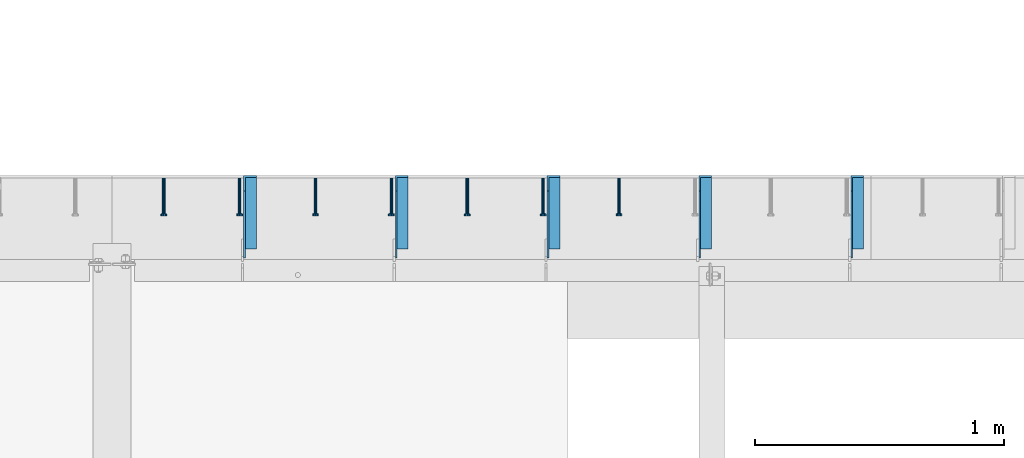
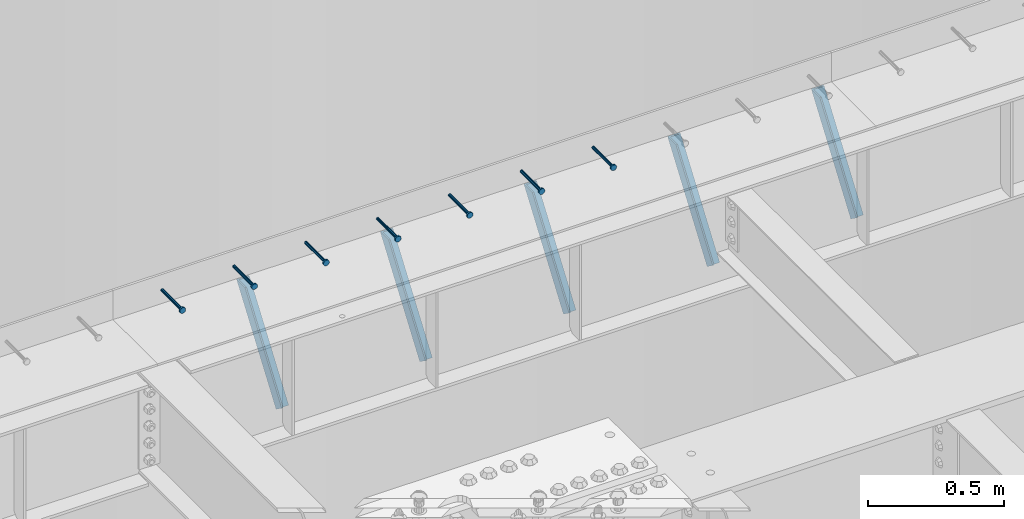
# One storey, part 1355 of 1763: 7 beams, 5 members, 8 elements without a shape of their own.
"""IFC2X3 building model written with IfcOpenShell, lengths in millimetres."""

from ifc_helpers import new_model, si_unit, frame, origin_with_axes, place, context, subcontext, project, spatial, faceted_brep, material, type_object, element, aggregate, save


model = new_model("IFC2X3")

# Units and contexts
model_context = context("Model", 3, precision=1e-05, world=origin_with_axes())
body_context = subcontext(model_context, "Body", "Model", "MODEL_VIEW")
ifc_project = project(units=[si_unit("LENGTHUNIT", "METRE", prefix="MILLI"), si_unit("AREAUNIT", "SQUARE_METRE"), si_unit("VOLUMEUNIT", "CUBIC_METRE"), si_unit("MASSUNIT", "GRAM", prefix="KILO"), si_unit("TIMEUNIT", "SECOND"), si_unit("PLANEANGLEUNIT", "RADIAN"), si_unit("SOLIDANGLEUNIT", "STERADIAN"), si_unit("THERMODYNAMICTEMPERATUREUNIT", "DEGREE_CELSIUS"), si_unit("LUMINOUSINTENSITYUNIT", "LUMEN")], contexts=[model_context])

# Site, building, storey
site_placement = place(None, origin_with_axes())
site = spatial("IfcSite", under=ifc_project, at=site_placement, CompositionType="ELEMENT")
building_placement = place(site_placement, origin_with_axes())
building = spatial("IfcBuilding", under=site, at=building_placement, Name="Undefined", CompositionType="ELEMENT")
storey_placement = place(building_placement, origin_with_axes())
storey = spatial("IfcBuildingStorey", under=building, at=storey_placement, Name="Undefined", CompositionType="ELEMENT", Elevation=0.0)

# Assembly, beam
assembly_1_placement = place(storey_placement, origin_with_axes())
assembly_1 = element("IfcElementAssembly", 1, at=assembly_1_placement, inside=storey, Name="HEADED STUD ANCHOR", AssemblyPlace="NOTDEFINED", PredefinedType="RIGID_FRAME")
ifc_material_1 = material(Name="STEEL/A108")
beam_type = type_object("IfcBeamType", PredefinedType="NOTDEFINED")
beam_1_placement = place(assembly_1_placement, frame((-47365.6747736983, 53984.5250183106, 5264.23140606069), z_axis=(0.0, 0.0, 1.0), x_axis=(0.0, -1.0, 0.0)))
beam_1 = element("IfcBeam", 2, at=beam_1_placement, type_object=beam_type, material=ifc_material_1, Name="HEADED STUD ANCHOR", context=body_context, shape_type="Brep", body=[
    faceted_brep([(0.0, -3.1800000667572, 5.5), (0.0, -5.5, 3.1800000667572), (141.732000000002, -5.5, 3.1800000667572), (141.732000000002, -3.1800000667572, 5.5), (0.0, -6.34999999999491, 1.45519152283669e-11), (141.732000000002, -6.34999990463257, 0.0), (0.0, -5.5, -3.1800000667572), (141.732000000002, -5.5, -3.1800000667572), (0.0, -3.1800000667572, -5.5), (141.732000000002, -3.1800000667572, -5.5), (0.0, 0.0, -6.34999990463257), (141.732000000002, 0.0, -6.34999990463257), (0.0, 3.1800000667572, -5.5), (141.732000000002, 3.1800000667572, -5.5), (0.0, 5.5, -3.1800000667572), (141.732000000002, 5.5, -3.1800000667572), (0.0, 6.34999999999491, -2.91038304567337e-11), (141.732000000002, 6.34999990463257, 0.0), (0.0, 5.5, 3.1800000667572), (141.732000000002, 5.5, 3.1800000667572), (0.0, 3.1800000667572, 5.5), (141.732000000002, 3.1800000667572, 5.5), (0.0, 0.0, 6.34999990463257), (141.732000000002, 0.0, 6.34999990463257), (144.780000000001, -10.9899997711182, 6.34999990463257), (144.780000000001, -6.34000015258789, 10.9899997711182), (144.780000000001, -12.6999998092651, 0.0), (144.780000000001, -10.9899997711182, -6.34999990463257), (144.780000000001, -6.34000015258789, -10.9899997711182), (144.780000000001, 0.0, -12.6899995803833), (144.780000000001, 6.34000015258789, -10.9899997711182), (144.780000000001, 10.9899997711182, -6.34999990463257), (144.780000000001, 12.6999998092651, 0.0), (144.780000000001, 10.9899997711182, 6.34999990463257), (144.780000000001, 6.34000015258789, 10.9899997711182), (144.780000000001, 0.0, 12.6899995803833), (152.400000000001, -10.9899997711182, 6.34999990463257), (152.400000000001, -6.34000015258789, 10.9899997711182), (152.400000000001, -12.6999998092651, 0.0), (152.400000000001, -10.9899997711182, -6.34999990463257), (152.400000000001, -6.34000015258789, -10.9899997711182), (152.400000000001, 0.0, -12.6899995803833), (152.400000000001, 6.34000015258789, -10.9899997711182), (152.400000000001, 10.9899997711182, -6.34999990463257), (152.400000000001, 12.6999998092651, 0.0), (152.400000000001, 10.9899997711182, 6.34999990463257), (152.400000000001, 6.34000015258789, 10.9899997711182), (152.400000000001, 0.0, 12.6899995803833)], [[[0, 1, 2, 3]], [[1, 4, 5, 2]], [[4, 6, 7, 5]], [[6, 8, 9, 7]], [[8, 10, 11, 9]], [[10, 12, 13, 11]], [[12, 14, 15, 13]], [[14, 16, 17, 15]], [[16, 18, 19, 17]], [[18, 20, 21, 19]], [[20, 22, 23, 21]], [[22, 0, 3, 23]], [[22, 20, 18, 16, 14, 12, 10, 8, 6, 4, 1, 0]], [[3, 2, 24, 25]], [[2, 5, 26, 24]], [[5, 7, 27, 26]], [[7, 9, 28, 27]], [[9, 11, 29, 28]], [[11, 13, 30, 29]], [[13, 15, 31, 30]], [[15, 17, 32, 31]], [[17, 19, 33, 32]], [[19, 21, 34, 33]], [[21, 23, 35, 34]], [[23, 3, 25, 35]], [[25, 24, 36, 37]], [[24, 26, 38, 36]], [[26, 27, 39, 38]], [[27, 28, 40, 39]], [[28, 29, 41, 40]], [[29, 30, 42, 41]], [[30, 31, 43, 42]], [[31, 32, 44, 43]], [[32, 33, 45, 44]], [[33, 34, 46, 45]], [[34, 35, 47, 46]], [[35, 25, 37, 47]], [[38, 39, 40, 41, 42, 43, 44, 45, 46, 47, 37, 36]]]),
])
aggregate(assembly_1, [beam_1])

assembly_2_placement = place(storey_placement, origin_with_axes())
assembly_2 = element("IfcElementAssembly", 3, at=assembly_2_placement, inside=storey, Name="HEADED STUD ANCHOR", AssemblyPlace="NOTDEFINED", PredefinedType="RIGID_FRAME")
beam_2_placement = place(assembly_2_placement, frame((-47670.4747736983, 53984.5250183106, 5264.23140606069), z_axis=(0.0, 0.0, 1.0), x_axis=(0.0, -1.0, 0.0)))
beam_2 = element("IfcBeam", 4, at=beam_2_placement, type_object=beam_type, material=ifc_material_1, Name="HEADED STUD ANCHOR", context=body_context, shape_type="Brep", body=[
    faceted_brep([(0.0, -3.1800000667572, 5.5), (0.0, -5.5, 3.1800000667572), (141.732000000002, -5.5, 3.1800000667572), (141.732000000002, -3.1800000667572, 5.5), (0.0, -6.34999999999491, 1.45519152283669e-11), (141.732000000002, -6.34999990463257, 0.0), (0.0, -5.5, -3.1800000667572), (141.732000000002, -5.5, -3.1800000667572), (0.0, -3.1800000667572, -5.5), (141.732000000002, -3.1800000667572, -5.5), (0.0, 0.0, -6.34999990463257), (141.732000000002, 0.0, -6.34999990463257), (0.0, 3.1800000667572, -5.5), (141.732000000002, 3.1800000667572, -5.5), (0.0, 5.5, -3.1800000667572), (141.732000000002, 5.5, -3.1800000667572), (0.0, 6.34999999999491, -2.91038304567337e-11), (141.732000000002, 6.34999990463257, 0.0), (0.0, 5.5, 3.1800000667572), (141.732000000002, 5.5, 3.1800000667572), (0.0, 3.1800000667572, 5.5), (141.732000000002, 3.1800000667572, 5.5), (0.0, 0.0, 6.34999990463257), (141.732000000002, 0.0, 6.34999990463257), (144.780000000001, -10.9899997711182, 6.34999990463257), (144.780000000001, -6.34000015258789, 10.9899997711182), (144.780000000001, -12.6999998092651, 0.0), (144.780000000001, -10.9899997711182, -6.34999990463257), (144.780000000001, -6.34000015258789, -10.9899997711182), (144.780000000001, 0.0, -12.6899995803833), (144.780000000001, 6.34000015258789, -10.9899997711182), (144.780000000001, 10.9899997711182, -6.34999990463257), (144.780000000001, 12.6999998092651, 0.0), (144.780000000001, 10.9899997711182, 6.34999990463257), (144.780000000001, 6.34000015258789, 10.9899997711182), (144.780000000001, 0.0, 12.6899995803833), (152.400000000001, -10.9899997711182, 6.34999990463257), (152.400000000001, -6.34000015258789, 10.9899997711182), (152.400000000001, -12.6999998092651, 0.0), (152.400000000001, -10.9899997711182, -6.34999990463257), (152.400000000001, -6.34000015258789, -10.9899997711182), (152.400000000001, 0.0, -12.6899995803833), (152.400000000001, 6.34000015258789, -10.9899997711182), (152.400000000001, 10.9899997711182, -6.34999990463257), (152.400000000001, 12.6999998092651, 0.0), (152.400000000001, 10.9899997711182, 6.34999990463257), (152.400000000001, 6.34000015258789, 10.9899997711182), (152.400000000001, 0.0, 12.6899995803833)], [[[0, 1, 2, 3]], [[1, 4, 5, 2]], [[4, 6, 7, 5]], [[6, 8, 9, 7]], [[8, 10, 11, 9]], [[10, 12, 13, 11]], [[12, 14, 15, 13]], [[14, 16, 17, 15]], [[16, 18, 19, 17]], [[18, 20, 21, 19]], [[20, 22, 23, 21]], [[22, 0, 3, 23]], [[22, 20, 18, 16, 14, 12, 10, 8, 6, 4, 1, 0]], [[3, 2, 24, 25]], [[2, 5, 26, 24]], [[5, 7, 27, 26]], [[7, 9, 28, 27]], [[9, 11, 29, 28]], [[11, 13, 30, 29]], [[13, 15, 31, 30]], [[15, 17, 32, 31]], [[17, 19, 33, 32]], [[19, 21, 34, 33]], [[21, 23, 35, 34]], [[23, 3, 25, 35]], [[25, 24, 36, 37]], [[24, 26, 38, 36]], [[26, 27, 39, 38]], [[27, 28, 40, 39]], [[28, 29, 41, 40]], [[29, 30, 42, 41]], [[30, 31, 43, 42]], [[31, 32, 44, 43]], [[32, 33, 45, 44]], [[33, 34, 46, 45]], [[34, 35, 47, 46]], [[35, 25, 37, 47]], [[38, 39, 40, 41, 42, 43, 44, 45, 46, 47, 37, 36]]]),
])
aggregate(assembly_2, [beam_2])

assembly_3_placement = place(storey_placement, origin_with_axes())
assembly_3 = element("IfcElementAssembly", 5, at=assembly_3_placement, inside=storey, Name="HEADED STUD ANCHOR", AssemblyPlace="NOTDEFINED", PredefinedType="RIGID_FRAME")
beam_3_placement = place(assembly_3_placement, frame((-47975.2747736983, 53984.5250183106, 5264.23140606069), z_axis=(0.0, 0.0, 1.0), x_axis=(0.0, -1.0, 0.0)))
beam_3 = element("IfcBeam", 6, at=beam_3_placement, type_object=beam_type, material=ifc_material_1, Name="HEADED STUD ANCHOR", context=body_context, shape_type="Brep", body=[
    faceted_brep([(0.0, -3.1800000667572, 5.5), (0.0, -5.5, 3.1800000667572), (141.732000000002, -5.5, 3.1800000667572), (141.732000000002, -3.1800000667572, 5.5), (0.0, -6.34999999999491, 1.45519152283669e-11), (141.732000000002, -6.34999990463257, 0.0), (0.0, -5.5, -3.1800000667572), (141.732000000002, -5.5, -3.1800000667572), (0.0, -3.1800000667572, -5.5), (141.732000000002, -3.1800000667572, -5.5), (0.0, 0.0, -6.34999990463257), (141.732000000002, 0.0, -6.34999990463257), (0.0, 3.1800000667572, -5.5), (141.732000000002, 3.1800000667572, -5.5), (0.0, 5.5, -3.1800000667572), (141.732000000002, 5.5, -3.1800000667572), (0.0, 6.34999999999491, -2.91038304567337e-11), (141.732000000002, 6.34999990463257, 0.0), (0.0, 5.5, 3.1800000667572), (141.732000000002, 5.5, 3.1800000667572), (0.0, 3.1800000667572, 5.5), (141.732000000002, 3.1800000667572, 5.5), (0.0, 0.0, 6.34999990463257), (141.732000000002, 0.0, 6.34999990463257), (144.780000000001, -10.9899997711182, 6.34999990463257), (144.780000000001, -6.34000015258789, 10.9899997711182), (144.780000000001, -12.6999998092651, 0.0), (144.780000000001, -10.9899997711182, -6.34999990463257), (144.780000000001, -6.34000015258789, -10.9899997711182), (144.780000000001, 0.0, -12.6899995803833), (144.780000000001, 6.34000015258789, -10.9899997711182), (144.780000000001, 10.9899997711182, -6.34999990463257), (144.780000000001, 12.6999998092651, 0.0), (144.780000000001, 10.9899997711182, 6.34999990463257), (144.780000000001, 6.34000015258789, 10.9899997711182), (144.780000000001, 0.0, 12.6899995803833), (152.400000000001, -10.9899997711182, 6.34999990463257), (152.400000000001, -6.34000015258789, 10.9899997711182), (152.400000000001, -12.6999998092651, 0.0), (152.400000000001, -10.9899997711182, -6.34999990463257), (152.400000000001, -6.34000015258789, -10.9899997711182), (152.400000000001, 0.0, -12.6899995803833), (152.400000000001, 6.34000015258789, -10.9899997711182), (152.400000000001, 10.9899997711182, -6.34999990463257), (152.400000000001, 12.6999998092651, 0.0), (152.400000000001, 10.9899997711182, 6.34999990463257), (152.400000000001, 6.34000015258789, 10.9899997711182), (152.400000000001, 0.0, 12.6899995803833)], [[[0, 1, 2, 3]], [[1, 4, 5, 2]], [[4, 6, 7, 5]], [[6, 8, 9, 7]], [[8, 10, 11, 9]], [[10, 12, 13, 11]], [[12, 14, 15, 13]], [[14, 16, 17, 15]], [[16, 18, 19, 17]], [[18, 20, 21, 19]], [[20, 22, 23, 21]], [[22, 0, 3, 23]], [[22, 20, 18, 16, 14, 12, 10, 8, 6, 4, 1, 0]], [[3, 2, 24, 25]], [[2, 5, 26, 24]], [[5, 7, 27, 26]], [[7, 9, 28, 27]], [[9, 11, 29, 28]], [[11, 13, 30, 29]], [[13, 15, 31, 30]], [[15, 17, 32, 31]], [[17, 19, 33, 32]], [[19, 21, 34, 33]], [[21, 23, 35, 34]], [[23, 3, 25, 35]], [[25, 24, 36, 37]], [[24, 26, 38, 36]], [[26, 27, 39, 38]], [[27, 28, 40, 39]], [[28, 29, 41, 40]], [[29, 30, 42, 41]], [[30, 31, 43, 42]], [[31, 32, 44, 43]], [[32, 33, 45, 44]], [[33, 34, 46, 45]], [[34, 35, 47, 46]], [[35, 25, 37, 47]], [[38, 39, 40, 41, 42, 43, 44, 45, 46, 47, 37, 36]]]),
])
aggregate(assembly_3, [beam_3])

assembly_4_placement = place(storey_placement, origin_with_axes())
assembly_4 = element("IfcElementAssembly", 7, at=assembly_4_placement, inside=storey, Name="HEADED STUD ANCHOR", AssemblyPlace="NOTDEFINED", PredefinedType="RIGID_FRAME")
beam_4_placement = place(assembly_4_placement, frame((-48280.0747736983, 53984.5250183106, 5264.23140606069), z_axis=(0.0, 0.0, 1.0), x_axis=(0.0, -1.0, 0.0)))
beam_4 = element("IfcBeam", 8, at=beam_4_placement, type_object=beam_type, material=ifc_material_1, Name="HEADED STUD ANCHOR", context=body_context, shape_type="Brep", body=[
    faceted_brep([(0.0, -3.1800000667572, 5.5), (0.0, -5.5, 3.1800000667572), (141.732000000002, -5.5, 3.1800000667572), (141.732000000002, -3.1800000667572, 5.5), (0.0, -6.34999999999491, 1.45519152283669e-11), (141.732000000002, -6.34999990463257, 0.0), (0.0, -5.5, -3.1800000667572), (141.732000000002, -5.5, -3.1800000667572), (0.0, -3.1800000667572, -5.5), (141.732000000002, -3.1800000667572, -5.5), (0.0, 0.0, -6.34999990463257), (141.732000000002, 0.0, -6.34999990463257), (0.0, 3.1800000667572, -5.5), (141.732000000002, 3.1800000667572, -5.5), (0.0, 5.5, -3.1800000667572), (141.732000000002, 5.5, -3.1800000667572), (0.0, 6.34999999999491, -2.91038304567337e-11), (141.732000000002, 6.34999990463257, 0.0), (0.0, 5.5, 3.1800000667572), (141.732000000002, 5.5, 3.1800000667572), (0.0, 3.1800000667572, 5.5), (141.732000000002, 3.1800000667572, 5.5), (0.0, 0.0, 6.34999990463257), (141.732000000002, 0.0, 6.34999990463257), (144.780000000001, -10.9899997711182, 6.34999990463257), (144.780000000001, -6.34000015258789, 10.9899997711182), (144.780000000001, -12.6999998092651, 0.0), (144.780000000001, -10.9899997711182, -6.34999990463257), (144.780000000001, -6.34000015258789, -10.9899997711182), (144.780000000001, 0.0, -12.6899995803833), (144.780000000001, 6.34000015258789, -10.9899997711182), (144.780000000001, 10.9899997711182, -6.34999990463257), (144.780000000001, 12.6999998092651, 0.0), (144.780000000001, 10.9899997711182, 6.34999990463257), (144.780000000001, 6.34000015258789, 10.9899997711182), (144.780000000001, 0.0, 12.6899995803833), (152.400000000001, -10.9899997711182, 6.34999990463257), (152.400000000001, -6.34000015258789, 10.9899997711182), (152.400000000001, -12.6999998092651, 0.0), (152.400000000001, -10.9899997711182, -6.34999990463257), (152.400000000001, -6.34000015258789, -10.9899997711182), (152.400000000001, 0.0, -12.6899995803833), (152.400000000001, 6.34000015258789, -10.9899997711182), (152.400000000001, 10.9899997711182, -6.34999990463257), (152.400000000001, 12.6999998092651, 0.0), (152.400000000001, 10.9899997711182, 6.34999990463257), (152.400000000001, 6.34000015258789, 10.9899997711182), (152.400000000001, 0.0, 12.6899995803833)], [[[0, 1, 2, 3]], [[1, 4, 5, 2]], [[4, 6, 7, 5]], [[6, 8, 9, 7]], [[8, 10, 11, 9]], [[10, 12, 13, 11]], [[12, 14, 15, 13]], [[14, 16, 17, 15]], [[16, 18, 19, 17]], [[18, 20, 21, 19]], [[20, 22, 23, 21]], [[22, 0, 3, 23]], [[22, 20, 18, 16, 14, 12, 10, 8, 6, 4, 1, 0]], [[3, 2, 24, 25]], [[2, 5, 26, 24]], [[5, 7, 27, 26]], [[7, 9, 28, 27]], [[9, 11, 29, 28]], [[11, 13, 30, 29]], [[13, 15, 31, 30]], [[15, 17, 32, 31]], [[17, 19, 33, 32]], [[19, 21, 34, 33]], [[21, 23, 35, 34]], [[23, 3, 25, 35]], [[25, 24, 36, 37]], [[24, 26, 38, 36]], [[26, 27, 39, 38]], [[27, 28, 40, 39]], [[28, 29, 41, 40]], [[29, 30, 42, 41]], [[30, 31, 43, 42]], [[31, 32, 44, 43]], [[32, 33, 45, 44]], [[33, 34, 46, 45]], [[34, 35, 47, 46]], [[35, 25, 37, 47]], [[38, 39, 40, 41, 42, 43, 44, 45, 46, 47, 37, 36]]]),
])
aggregate(assembly_4, [beam_4])

assembly_5_placement = place(storey_placement, origin_with_axes())
assembly_5 = element("IfcElementAssembly", 9, at=assembly_5_placement, inside=storey, Name="HEADED STUD ANCHOR", AssemblyPlace="NOTDEFINED", PredefinedType="RIGID_FRAME")
beam_5_placement = place(assembly_5_placement, frame((-48584.8747736983, 53984.5250183106, 5264.23140606069), z_axis=(0.0, 0.0, 1.0), x_axis=(0.0, -1.0, 0.0)))
beam_5 = element("IfcBeam", 10, at=beam_5_placement, type_object=beam_type, material=ifc_material_1, Name="HEADED STUD ANCHOR", context=body_context, shape_type="Brep", body=[
    faceted_brep([(0.0, -3.1800000667572, 5.5), (0.0, -5.5, 3.1800000667572), (141.732000000002, -5.5, 3.1800000667572), (141.732000000002, -3.1800000667572, 5.5), (0.0, -6.34999999999491, 1.45519152283669e-11), (141.732000000002, -6.34999990463257, 0.0), (0.0, -5.5, -3.1800000667572), (141.732000000002, -5.5, -3.1800000667572), (0.0, -3.1800000667572, -5.5), (141.732000000002, -3.1800000667572, -5.5), (0.0, 0.0, -6.34999990463257), (141.732000000002, 0.0, -6.34999990463257), (0.0, 3.1800000667572, -5.5), (141.732000000002, 3.1800000667572, -5.5), (0.0, 5.5, -3.1800000667572), (141.732000000002, 5.5, -3.1800000667572), (0.0, 6.34999999999491, -2.91038304567337e-11), (141.732000000002, 6.34999990463257, 0.0), (0.0, 5.5, 3.1800000667572), (141.732000000002, 5.5, 3.1800000667572), (0.0, 3.1800000667572, 5.5), (141.732000000002, 3.1800000667572, 5.5), (0.0, 0.0, 6.34999990463257), (141.732000000002, 0.0, 6.34999990463257), (144.780000000001, -10.9899997711182, 6.34999990463257), (144.780000000001, -6.34000015258789, 10.9899997711182), (144.780000000001, -12.6999998092651, 0.0), (144.780000000001, -10.9899997711182, -6.34999990463257), (144.780000000001, -6.34000015258789, -10.9899997711182), (144.780000000001, 0.0, -12.6899995803833), (144.780000000001, 6.34000015258789, -10.9899997711182), (144.780000000001, 10.9899997711182, -6.34999990463257), (144.780000000001, 12.6999998092651, 0.0), (144.780000000001, 10.9899997711182, 6.34999990463257), (144.780000000001, 6.34000015258789, 10.9899997711182), (144.780000000001, 0.0, 12.6899995803833), (152.400000000001, -10.9899997711182, 6.34999990463257), (152.400000000001, -6.34000015258789, 10.9899997711182), (152.400000000001, -12.6999998092651, 0.0), (152.400000000001, -10.9899997711182, -6.34999990463257), (152.400000000001, -6.34000015258789, -10.9899997711182), (152.400000000001, 0.0, -12.6899995803833), (152.400000000001, 6.34000015258789, -10.9899997711182), (152.400000000001, 10.9899997711182, -6.34999990463257), (152.400000000001, 12.6999998092651, 0.0), (152.400000000001, 10.9899997711182, 6.34999990463257), (152.400000000001, 6.34000015258789, 10.9899997711182), (152.400000000001, 0.0, 12.6899995803833)], [[[0, 1, 2, 3]], [[1, 4, 5, 2]], [[4, 6, 7, 5]], [[6, 8, 9, 7]], [[8, 10, 11, 9]], [[10, 12, 13, 11]], [[12, 14, 15, 13]], [[14, 16, 17, 15]], [[16, 18, 19, 17]], [[18, 20, 21, 19]], [[20, 22, 23, 21]], [[22, 0, 3, 23]], [[22, 20, 18, 16, 14, 12, 10, 8, 6, 4, 1, 0]], [[3, 2, 24, 25]], [[2, 5, 26, 24]], [[5, 7, 27, 26]], [[7, 9, 28, 27]], [[9, 11, 29, 28]], [[11, 13, 30, 29]], [[13, 15, 31, 30]], [[15, 17, 32, 31]], [[17, 19, 33, 32]], [[19, 21, 34, 33]], [[21, 23, 35, 34]], [[23, 3, 25, 35]], [[25, 24, 36, 37]], [[24, 26, 38, 36]], [[26, 27, 39, 38]], [[27, 28, 40, 39]], [[28, 29, 41, 40]], [[29, 30, 42, 41]], [[30, 31, 43, 42]], [[31, 32, 44, 43]], [[32, 33, 45, 44]], [[33, 34, 46, 45]], [[34, 35, 47, 46]], [[35, 25, 37, 47]], [[38, 39, 40, 41, 42, 43, 44, 45, 46, 47, 37, 36]]]),
])
aggregate(assembly_5, [beam_5])

assembly_6_placement = place(storey_placement, origin_with_axes())
assembly_6 = element("IfcElementAssembly", 11, at=assembly_6_placement, inside=storey, Name="HEADED STUD ANCHOR", AssemblyPlace="NOTDEFINED", PredefinedType="RIGID_FRAME")
beam_6_placement = place(assembly_6_placement, frame((-48889.6747736983, 53984.5250183106, 5264.23140606069), z_axis=(0.0, 0.0, 1.0), x_axis=(0.0, -1.0, 0.0)))
beam_6 = element("IfcBeam", 12, at=beam_6_placement, type_object=beam_type, material=ifc_material_1, Name="HEADED STUD ANCHOR", context=body_context, shape_type="Brep", body=[
    faceted_brep([(0.0, -3.1800000667572, 5.5), (0.0, -5.5, 3.1800000667572), (141.732000000002, -5.5, 3.1800000667572), (141.732000000002, -3.1800000667572, 5.5), (0.0, -6.34999999999491, 1.45519152283669e-11), (141.732000000002, -6.34999990463257, 0.0), (0.0, -5.5, -3.1800000667572), (141.732000000002, -5.5, -3.1800000667572), (0.0, -3.1800000667572, -5.5), (141.732000000002, -3.1800000667572, -5.5), (0.0, 0.0, -6.34999990463257), (141.732000000002, 0.0, -6.34999990463257), (0.0, 3.1800000667572, -5.5), (141.732000000002, 3.1800000667572, -5.5), (0.0, 5.5, -3.1800000667572), (141.732000000002, 5.5, -3.1800000667572), (0.0, 6.34999999999491, -2.91038304567337e-11), (141.732000000002, 6.34999990463257, 0.0), (0.0, 5.5, 3.1800000667572), (141.732000000002, 5.5, 3.1800000667572), (0.0, 3.1800000667572, 5.5), (141.732000000002, 3.1800000667572, 5.5), (0.0, 0.0, 6.34999990463257), (141.732000000002, 0.0, 6.34999990463257), (144.780000000001, -10.9899997711182, 6.34999990463257), (144.780000000001, -6.34000015258789, 10.9899997711182), (144.780000000001, -12.6999998092651, 0.0), (144.780000000001, -10.9899997711182, -6.34999990463257), (144.780000000001, -6.34000015258789, -10.9899997711182), (144.780000000001, 0.0, -12.6899995803833), (144.780000000001, 6.34000015258789, -10.9899997711182), (144.780000000001, 10.9899997711182, -6.34999990463257), (144.780000000001, 12.6999998092651, 0.0), (144.780000000001, 10.9899997711182, 6.34999990463257), (144.780000000001, 6.34000015258789, 10.9899997711182), (144.780000000001, 0.0, 12.6899995803833), (152.400000000001, -10.9899997711182, 6.34999990463257), (152.400000000001, -6.34000015258789, 10.9899997711182), (152.400000000001, -12.6999998092651, 0.0), (152.400000000001, -10.9899997711182, -6.34999990463257), (152.400000000001, -6.34000015258789, -10.9899997711182), (152.400000000001, 0.0, -12.6899995803833), (152.400000000001, 6.34000015258789, -10.9899997711182), (152.400000000001, 10.9899997711182, -6.34999990463257), (152.400000000001, 12.6999998092651, 0.0), (152.400000000001, 10.9899997711182, 6.34999990463257), (152.400000000001, 6.34000015258789, 10.9899997711182), (152.400000000001, 0.0, 12.6899995803833)], [[[0, 1, 2, 3]], [[1, 4, 5, 2]], [[4, 6, 7, 5]], [[6, 8, 9, 7]], [[8, 10, 11, 9]], [[10, 12, 13, 11]], [[12, 14, 15, 13]], [[14, 16, 17, 15]], [[16, 18, 19, 17]], [[18, 20, 21, 19]], [[20, 22, 23, 21]], [[22, 0, 3, 23]], [[22, 20, 18, 16, 14, 12, 10, 8, 6, 4, 1, 0]], [[3, 2, 24, 25]], [[2, 5, 26, 24]], [[5, 7, 27, 26]], [[7, 9, 28, 27]], [[9, 11, 29, 28]], [[11, 13, 30, 29]], [[13, 15, 31, 30]], [[15, 17, 32, 31]], [[17, 19, 33, 32]], [[19, 21, 34, 33]], [[21, 23, 35, 34]], [[23, 3, 25, 35]], [[25, 24, 36, 37]], [[24, 26, 38, 36]], [[26, 27, 39, 38]], [[27, 28, 40, 39]], [[28, 29, 41, 40]], [[29, 30, 42, 41]], [[30, 31, 43, 42]], [[31, 32, 44, 43]], [[32, 33, 45, 44]], [[33, 34, 46, 45]], [[34, 35, 47, 46]], [[35, 25, 37, 47]], [[38, 39, 40, 41, 42, 43, 44, 45, 46, 47, 37, 36]]]),
])
aggregate(assembly_6, [beam_6])

assembly_7_placement = place(storey_placement, origin_with_axes())
assembly_7 = element("IfcElementAssembly", 13, at=assembly_7_placement, inside=storey, Name="HEADED STUD ANCHOR", AssemblyPlace="NOTDEFINED", PredefinedType="RIGID_FRAME")
beam_7_placement = place(assembly_7_placement, frame((-49194.4747736983, 53984.5250183106, 5264.23140606069), z_axis=(0.0, 0.0, 1.0), x_axis=(0.0, -1.0, 0.0)))
beam_7 = element("IfcBeam", 14, at=beam_7_placement, type_object=beam_type, material=ifc_material_1, Name="HEADED STUD ANCHOR", context=body_context, shape_type="Brep", body=[
    faceted_brep([(0.0, -3.1800000667572, 5.5), (0.0, -5.5, 3.1800000667572), (141.732000000002, -5.5, 3.1800000667572), (141.732000000002, -3.1800000667572, 5.5), (0.0, -6.34999999999491, 1.45519152283669e-11), (141.732000000002, -6.34999990463257, 0.0), (0.0, -5.5, -3.1800000667572), (141.732000000002, -5.5, -3.1800000667572), (0.0, -3.1800000667572, -5.5), (141.732000000002, -3.1800000667572, -5.5), (0.0, 0.0, -6.34999990463257), (141.732000000002, 0.0, -6.34999990463257), (0.0, 3.1800000667572, -5.5), (141.732000000002, 3.1800000667572, -5.5), (0.0, 5.5, -3.1800000667572), (141.732000000002, 5.5, -3.1800000667572), (0.0, 6.34999999999491, -2.91038304567337e-11), (141.732000000002, 6.34999990463257, 0.0), (0.0, 5.5, 3.1800000667572), (141.732000000002, 5.5, 3.1800000667572), (0.0, 3.1800000667572, 5.5), (141.732000000002, 3.1800000667572, 5.5), (0.0, 0.0, 6.34999990463257), (141.732000000002, 0.0, 6.34999990463257), (144.780000000001, -10.9899997711182, 6.34999990463257), (144.780000000001, -6.34000015258789, 10.9899997711182), (144.780000000001, -12.6999998092651, 0.0), (144.780000000001, -10.9899997711182, -6.34999990463257), (144.780000000001, -6.34000015258789, -10.9899997711182), (144.780000000001, 0.0, -12.6899995803833), (144.780000000001, 6.34000015258789, -10.9899997711182), (144.780000000001, 10.9899997711182, -6.34999990463257), (144.780000000001, 12.6999998092651, 0.0), (144.780000000001, 10.9899997711182, 6.34999990463257), (144.780000000001, 6.34000015258789, 10.9899997711182), (144.780000000001, 0.0, 12.6899995803833), (152.400000000001, -10.9899997711182, 6.34999990463257), (152.400000000001, -6.34000015258789, 10.9899997711182), (152.400000000001, -12.6999998092651, 0.0), (152.400000000001, -10.9899997711182, -6.34999990463257), (152.400000000001, -6.34000015258789, -10.9899997711182), (152.400000000001, 0.0, -12.6899995803833), (152.400000000001, 6.34000015258789, -10.9899997711182), (152.400000000001, 10.9899997711182, -6.34999990463257), (152.400000000001, 12.6999998092651, 0.0), (152.400000000001, 10.9899997711182, 6.34999990463257), (152.400000000001, 6.34000015258789, 10.9899997711182), (152.400000000001, 0.0, 12.6899995803833)], [[[0, 1, 2, 3]], [[1, 4, 5, 2]], [[4, 6, 7, 5]], [[6, 8, 9, 7]], [[8, 10, 11, 9]], [[10, 12, 13, 11]], [[12, 14, 15, 13]], [[14, 16, 17, 15]], [[16, 18, 19, 17]], [[18, 20, 21, 19]], [[20, 22, 23, 21]], [[22, 0, 3, 23]], [[22, 20, 18, 16, 14, 12, 10, 8, 6, 4, 1, 0]], [[3, 2, 24, 25]], [[2, 5, 26, 24]], [[5, 7, 27, 26]], [[7, 9, 28, 27]], [[9, 11, 29, 28]], [[11, 13, 30, 29]], [[13, 15, 31, 30]], [[15, 17, 32, 31]], [[17, 19, 33, 32]], [[19, 21, 34, 33]], [[21, 23, 35, 34]], [[23, 3, 25, 35]], [[25, 24, 36, 37]], [[24, 26, 38, 36]], [[26, 27, 39, 38]], [[27, 28, 40, 39]], [[28, 29, 41, 40]], [[29, 30, 42, 41]], [[30, 31, 43, 42]], [[31, 32, 44, 43]], [[32, 33, 45, 44]], [[33, 34, 46, 45]], [[34, 35, 47, 46]], [[35, 25, 37, 47]], [[38, 39, 40, 41, 42, 43, 44, 45, 46, 47, 37, 36]]]),
])
aggregate(assembly_7, [beam_7])

# Assembly, members
assembly_8_placement = place(storey_placement, origin_with_axes())
assembly_8 = element("IfcElementAssembly", 15, at=assembly_8_placement, inside=storey, Name="BEAM", AssemblyPlace="NOTDEFINED", PredefinedType="RIGID_FRAME")
ifc_material_2 = material(Name="STEEL/A36")
member_type = type_object("IfcMemberType", Name="L2X2X1/4", PredefinedType="NOTDEFINED")
member_1_placement = place(assembly_8_placement, frame((-47019.0044734054, 53682.708383399, 4801.55161052505), z_axis=(0.0, -0.814117947745209, 0.580699549818259), x_axis=(0.0, 0.58069954981826, 0.814117947745209)))
member_1 = element("IfcMember", 16, at=member_1_placement, type_object=member_type, material=ifc_material_2, Name="ANGLE", ObjectType="L2X2X1/4", context=body_context, shape_type="Brep", body=[
    faceted_brep([(-1.45519152283669e-11, 25.4000000000015, -25.3999999999869), (1.45519152283669e-11, 25.4000000000015, 25.3999999999796), (464.304493432646, 25.4000000000015, 25.3999999991429), (500.539460322936, 25.4000000000015, -25.4000000009546), (1.45519152283669e-11, 19.0499999999993, 25.3999999999796), (464.304493432646, 19.0500000000029, 25.3999999991429), (-7.27595761418343e-12, 19.0499999999993, -19.0499999999956), (496.010089461648, 19.0500000000029, -19.0500000009415), (-7.27595761418343e-12, -25.4000000000015, -19.0499999999956), (496.010089461648, -25.4000000000015, -19.0500000009415), (-1.45519152283669e-11, -25.4000000000015, -25.3999999999869), (500.539460322936, -25.4000000000015, -25.4000000009546)], [[[0, 1, 2, 3]], [[1, 4, 5, 2]], [[4, 6, 7, 5]], [[6, 8, 9, 7]], [[8, 10, 11, 9]], [[10, 0, 3, 11]], [[5, 7, 9, 11, 3, 2]], [[10, 8, 6, 4, 1, 0]]]),
])
member_2_placement = place(assembly_8_placement, frame((-48238.2044734054, 53682.7083833989, 4801.55161052503), z_axis=(0.0, -0.814117947745209, 0.580699549818259), x_axis=(0.0, 0.58069954981826, 0.814117947745209)))
member_2 = element("IfcMember", 17, at=member_2_placement, type_object=member_type, material=ifc_material_2, Name="ANGLE", ObjectType="L2X2X1/4", context=body_context, shape_type="Brep", body=[
    faceted_brep([(-1.45519152283669e-11, 25.4000000000015, -25.3999999999869), (1.45519152283669e-11, 25.4000000000015, 25.3999999999796), (464.304493432646, 25.4000000000015, 25.3999999991429), (500.539460322936, 25.4000000000015, -25.4000000009546), (1.45519152283669e-11, 19.0499999999993, 25.3999999999796), (464.304493432646, 19.0500000000029, 25.3999999991429), (-7.27595761418343e-12, 19.0499999999993, -19.0499999999956), (496.010089461648, 19.0500000000029, -19.0500000009415), (-7.27595761418343e-12, -25.4000000000015, -19.0499999999956), (496.010089461648, -25.4000000000015, -19.0500000009415), (-1.45519152283669e-11, -25.4000000000015, -25.3999999999869), (500.539460322936, -25.4000000000015, -25.4000000009546)], [[[0, 1, 2, 3]], [[1, 4, 5, 2]], [[4, 6, 7, 5]], [[6, 8, 9, 7]], [[8, 10, 11, 9]], [[10, 0, 3, 11]], [[5, 7, 9, 11, 3, 2]], [[10, 8, 6, 4, 1, 0]]]),
])
member_3_placement = place(assembly_8_placement, frame((-46409.4044734054, 53682.708383399, 4801.55161052505), z_axis=(0.0, -0.814117947745209, 0.580699549818259), x_axis=(0.0, 0.58069954981826, 0.814117947745209)))
member_3 = element("IfcMember", 18, at=member_3_placement, type_object=member_type, material=ifc_material_2, Name="ANGLE", ObjectType="L2X2X1/4", context=body_context, shape_type="Brep", body=[
    faceted_brep([(-1.45519152283669e-11, 25.4000000000015, -25.3999999999869), (1.45519152283669e-11, 25.4000000000015, 25.3999999999796), (464.304493432646, 25.4000000000015, 25.3999999991429), (500.539460322936, 25.4000000000015, -25.4000000009546), (1.45519152283669e-11, 19.0499999999993, 25.3999999999796), (464.304493432646, 19.0500000000029, 25.3999999991429), (-7.27595761418343e-12, 19.0499999999993, -19.0499999999956), (496.010089461648, 19.0500000000029, -19.0500000009415), (-7.27595761418343e-12, -25.4000000000015, -19.0499999999956), (496.010089461648, -25.4000000000015, -19.0500000009415), (-1.45519152283669e-11, -25.4000000000015, -25.3999999999869), (500.539460322936, -25.4000000000015, -25.4000000009546)], [[[0, 1, 2, 3]], [[1, 4, 5, 2]], [[4, 6, 7, 5]], [[6, 8, 9, 7]], [[8, 10, 11, 9]], [[10, 0, 3, 11]], [[5, 7, 9, 11, 3, 2]], [[10, 8, 6, 4, 1, 0]]]),
])
member_4_placement = place(assembly_8_placement, frame((-47628.6044734054, 53682.708383399, 4801.55161052505), z_axis=(0.0, -0.814117947745209, 0.580699549818259), x_axis=(0.0, 0.58069954981826, 0.814117947745209)))
member_4 = element("IfcMember", 19, at=member_4_placement, type_object=member_type, material=ifc_material_2, Name="ANGLE", ObjectType="L2X2X1/4", context=body_context, shape_type="Brep", body=[
    faceted_brep([(-1.45519152283669e-11, 25.4000000000015, -25.3999999999869), (1.45519152283669e-11, 25.4000000000015, 25.3999999999796), (464.304493432646, 25.4000000000015, 25.3999999991429), (500.539460322936, 25.4000000000015, -25.4000000009546), (1.45519152283669e-11, 19.0499999999993, 25.3999999999796), (464.304493432646, 19.0500000000029, 25.3999999991429), (-7.27595761418343e-12, 19.0499999999993, -19.0499999999956), (496.010089461648, 19.0500000000029, -19.0500000009415), (-7.27595761418343e-12, -25.4000000000015, -19.0499999999956), (496.010089461648, -25.4000000000015, -19.0500000009415), (-1.45519152283669e-11, -25.4000000000015, -25.3999999999869), (500.539460322936, -25.4000000000015, -25.4000000009546)], [[[0, 1, 2, 3]], [[1, 4, 5, 2]], [[4, 6, 7, 5]], [[6, 8, 9, 7]], [[8, 10, 11, 9]], [[10, 0, 3, 11]], [[5, 7, 9, 11, 3, 2]], [[10, 8, 6, 4, 1, 0]]]),
])
member_5_placement = place(assembly_8_placement, frame((-48847.8044734054, 53682.7083833989, 4801.55161052503), z_axis=(0.0, -0.814117947745209, 0.580699549818259), x_axis=(0.0, 0.58069954981826, 0.814117947745209)))
member_5 = element("IfcMember", 20, at=member_5_placement, type_object=member_type, material=ifc_material_2, Name="ANGLE", ObjectType="L2X2X1/4", context=body_context, shape_type="Brep", body=[
    faceted_brep([(-1.45519152283669e-11, 25.4000000000015, -25.3999999999869), (1.45519152283669e-11, 25.4000000000015, 25.3999999999796), (464.304493432646, 25.4000000000015, 25.3999999991429), (500.539460322936, 25.4000000000015, -25.4000000009546), (1.45519152283669e-11, 19.0499999999993, 25.3999999999796), (464.304493432646, 19.0500000000029, 25.3999999991429), (-7.27595761418343e-12, 19.0499999999993, -19.0499999999956), (496.010089461648, 19.0500000000029, -19.0500000009415), (-7.27595761418343e-12, -25.4000000000015, -19.0499999999956), (496.010089461648, -25.4000000000015, -19.0500000009415), (-1.45519152283669e-11, -25.4000000000015, -25.3999999999869), (500.539460322936, -25.4000000000015, -25.4000000009546)], [[[0, 1, 2, 3]], [[1, 4, 5, 2]], [[4, 6, 7, 5]], [[6, 8, 9, 7]], [[8, 10, 11, 9]], [[10, 0, 3, 11]], [[5, 7, 9, 11, 3, 2]], [[10, 8, 6, 4, 1, 0]]]),
])
aggregate(assembly_8, [member_1, member_2, member_3, member_4, member_5])

save(model, "model.ifc")
